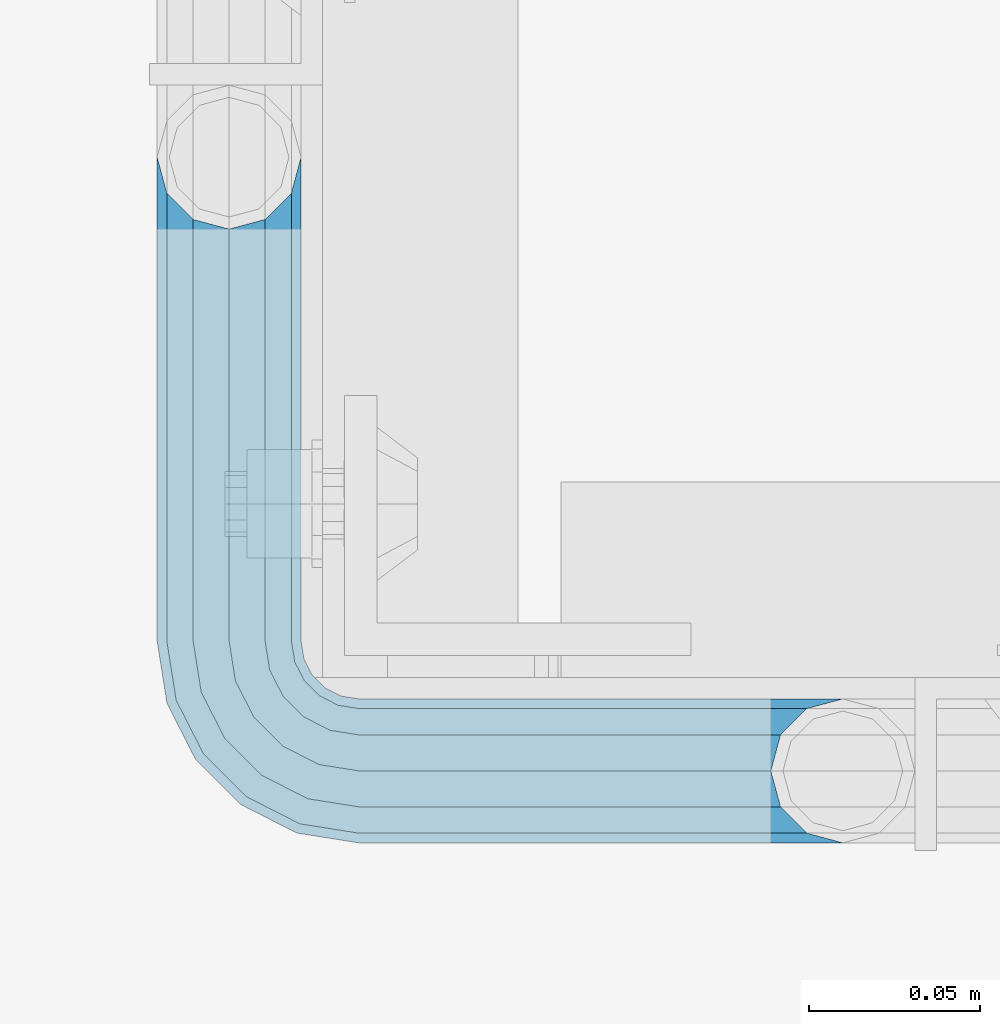
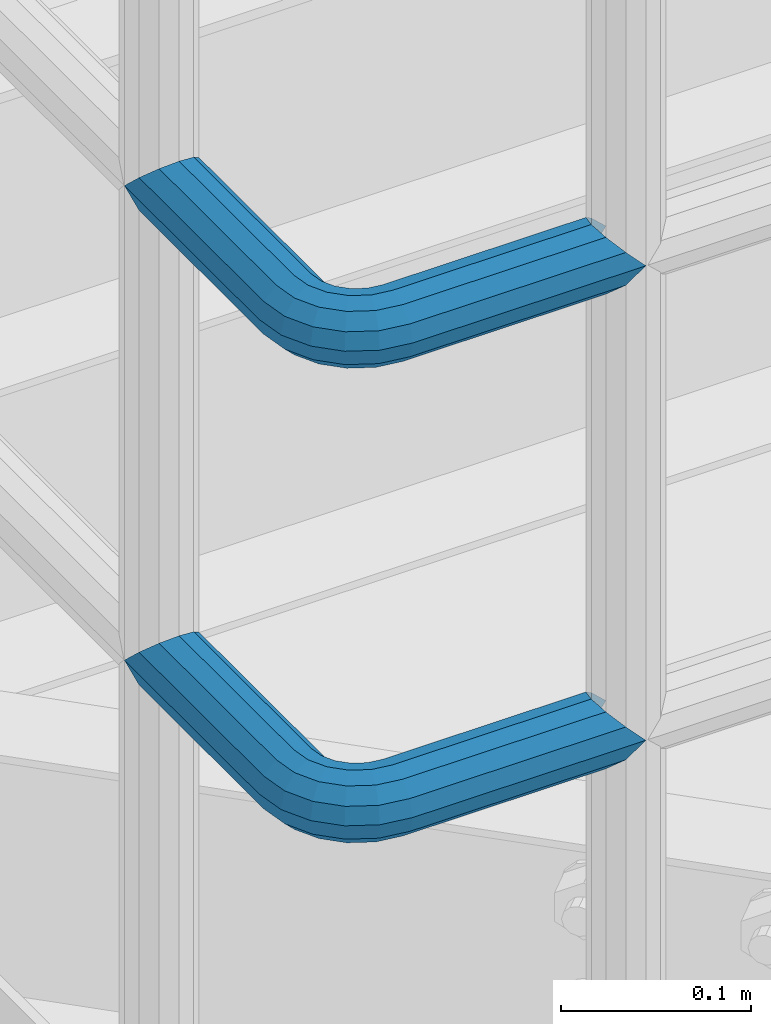
# One storey, part 1099 of 1876: 2 beams, 1 element without a shape of its own.
"""IFC2X3 building model written with IfcOpenShell, lengths in millimetres."""

from ifc_helpers import new_model, si_unit, frame, origin_with_axes, place, context, subcontext, project, spatial, faceted_brep, material, type_object, element, aggregate, save


model = new_model("IFC2X3")

# Units and contexts
model_context = context("Model", 3, precision=1e-05, world=origin_with_axes())
body_context = subcontext(model_context, "Body", "Model", "MODEL_VIEW")
ifc_project = project(units=[si_unit("LENGTHUNIT", "METRE", prefix="MILLI"), si_unit("AREAUNIT", "SQUARE_METRE"), si_unit("VOLUMEUNIT", "CUBIC_METRE"), si_unit("MASSUNIT", "GRAM", prefix="KILO"), si_unit("TIMEUNIT", "SECOND"), si_unit("PLANEANGLEUNIT", "RADIAN"), si_unit("SOLIDANGLEUNIT", "STERADIAN"), si_unit("THERMODYNAMICTEMPERATUREUNIT", "DEGREE_CELSIUS"), si_unit("LUMINOUSINTENSITYUNIT", "LUMEN")], contexts=[model_context])

# Site, building, storey
site_placement = place(None, origin_with_axes())
site = spatial("IfcSite", under=ifc_project, at=site_placement, CompositionType="ELEMENT")
building_placement = place(site_placement, origin_with_axes())
building = spatial("IfcBuilding", under=site, at=building_placement, Name="Undefined", CompositionType="ELEMENT")
storey_placement = place(building_placement, origin_with_axes())
storey = spatial("IfcBuildingStorey", under=building, at=storey_placement, Name="Undefined", CompositionType="ELEMENT", Elevation=0.0)

# Assembly, beams
assembly_placement = place(storey_placement, origin_with_axes())
assembly = element("IfcElementAssembly", 1, at=assembly_placement, inside=storey, Name="HANDRAIL", AssemblyPlace="NOTDEFINED", PredefinedType="RIGID_FRAME")
ifc_material = material()
beam_type = type_object("IfcBeamType", Name="PIPE1-1/4STD", PredefinedType="NOTDEFINED")
beam_1_placement = place(assembly_placement, frame((3338.06943150122, -15252.6644042969, 8480.425), z_axis=(0.0, 0.0, -1.0), x_axis=(0.0, -1.0, 0.0)))
beam_1 = element("IfcBeam", 2, at=beam_1_placement, type_object=beam_type, material=ifc_material, Name="HANDRAIL", ObjectType="PIPE1-1/4STD", context=body_context, shape_type="Brep", body=[
    faceted_brep([(9.09494701772928e-13, 21.0820000000003, 0.0), (10.5409999957128, 18.2575475579433, -10.5409999999993), (10.5409999999983, 18.2575475625836, 10.5410000000011), (10.5409999999983, -18.2575475625836, 10.5410000000011), (10.5409999957128, -18.2575475672238, -10.5409999999993), (9.09494701772928e-13, -21.0820000000003, 0.0), (18.2575475625817, -10.5410000000011, 18.2575475625836), (18.2575475625817, -10.5409999999974, 13.3999612267289), (13.6205863358537, -15.1779612267255, 8.76300000000083), (11.2725475625793, -17.5259999999998, 0.0), (13.6205863358537, -15.1779612267255, -8.76299999999901), (18.2575475625817, -10.5409999999974, -13.3999612267271), (18.2575475625817, -10.5410000000011, -18.2575475625836), (21.0819999999985, 0.0, -17.5259999999998), (21.0819999999985, 0.0, -21.0819999999985), (18.7339612267233, -8.76300000000083, -15.1779612267255), (18.7339612267251, 8.76299999999901, -15.1779612267255), (18.2575475625817, 10.5410000000011, -13.3999612267235), (18.2575475625817, 10.5409999999993, -18.2575475625836), (13.6205863358573, 15.1779612267255, -8.76299999999901), (11.2725475625839, 17.5259999999998, 0.0), (13.6205863358573, 15.1779612267255, 8.76300000000083), (18.2575475625817, 10.5410000000011, 13.3999612267253), (18.2575475625817, 10.5409999999993, 18.2575475625836), (18.7339612267251, 8.76299999999901, 15.1779612267273), (21.0819999999985, 1.81898940354586e-12, 17.5259999999998), (21.0819999999985, 1.81898940354586e-12, 21.0820000000003), (18.7339612267233, -8.76300000000083, 15.1779612267273), (141.7320022583, -8.7629999999981, 15.1779612267255), (141.7320022583, 1.81898940354586e-12, 17.525999999998), (153.505549272468, -1.86474665447258, 17.525999999998), (150.797633350759, -10.1988549067664, 15.1779612267237), (141.7320022583, -15.1779612267246, 8.76299999999901), (148.815301313444, -16.2998455832249, 8.76299999999901), (141.732002258301, -17.5259999999989, -1.81898940354586e-12), (148.08971742905, -18.5329631590612, -1.81898940354586e-12), (141.7320022583, -15.1779612267246, -8.76300000000083), (148.815301313443, -16.2998455832249, -8.76300000000083), (141.7320022583, -8.76299999999901, -15.1779612267273), (150.797633350759, -10.1988549067664, -15.1779612267273), (141.7320022583, 1.81898940354586e-12, -17.5260000000017), (153.505549272467, -1.86474665447258, -17.5260000000017), (141.7320022583, 8.76300000000174, -15.1779612267273), (156.213465194176, 6.46936159782217, -15.1779612267273), (141.7320022583, 15.1779612267273, -8.76300000000083), (158.195797231491, 12.5703522742806, -8.76300000000083), (141.7320022583, 17.5260000000017, -1.81898940354586e-12), (158.921381115884, 14.803469850116, -1.81898940354586e-12), (141.7320022583, 15.1779612267273, 8.76299999999901), (158.195797231491, 12.5703522742806, 8.76299999999901), (141.7320022583, 8.76300000000174, 15.1779612267255), (156.213465194176, 6.46936159782217, 15.1779612267237), (179.832000732422, -38.0999984741202, -17.5260000000017), (171.069000732422, -38.0999984741202, -15.1779612267273), (171.069000732422, -161.097989750122, -15.1779612267255), (179.832000732422, -158.7499511731, -17.5259999999998), (188.595000732423, -38.0999984741202, -15.1779612267273), (188.595000732422, -161.097990142627, -15.1779612267255), (169.291000732422, -38.0999984741202, -18.2575475625854), (179.832000732422, -38.0999984741202, -21.0820000000003), (179.832000732422, -158.7499511731, -21.0820000000003), (169.291000732422, -161.574403610517, -18.2575475625836), (161.574453169838, -38.0999984741193, -10.5410000000011), (161.574453169838, -169.2909511731, -10.5409999999993), (158.750000732422, -38.0999984741193, -1.81898940354586e-12), (158.750000732422, -179.831954956055, 0.0), (161.574453169838, -169.2909511731, 10.5409999999993), (161.574453169839, -38.0999984741193, 10.5409999999993), (169.291000732423, -38.0999984741193, 18.2575475625817), (169.291000732422, -161.574403610517, 18.2575475625836), (179.832000732423, -38.0999984741193, 21.0819999999985), (179.832000732422, -158.7499511731, 21.0820000000003), (141.7320022583, 10.5410000000011, 18.2575475625817), (141.7320022583, 18.2575475625854, 10.5409999999993), (141.7320022583, 21.0820000000012, -1.81898940354586e-12), (141.7320022583, 18.2575475625854, -10.5410000000011), (141.7320022583, 10.5410000000011, -18.2575475625854), (141.7320022583, 1.81898940354586e-12, -21.0820000000022), (141.7320022583, -10.5409999999983, -18.2575475625854), (141.7320022583, -18.2575475625817, -10.5410000000011), (141.732002258301, -21.0819999999985, -1.81898940354586e-12), (141.7320022583, -18.2575475625817, 10.5409999999993), (141.7320022583, -10.5409999999983, 18.2575475625817), (141.7320022583, 1.81898940354586e-12, 21.0819999999985), (153.505549272468, -1.86474665447258, 21.0819999999985), (156.762897410175, 8.16034008379484, 18.2575475625817), (159.147441744916, 15.4992129264911, 10.5409999999993), (160.020245547882, 18.1854268220623, -1.81898940354586e-12), (159.147441744916, 15.4992129264911, -10.5410000000011), (156.762897410174, 8.16034008379484, -18.2575475625854), (153.505549272467, -1.86474665447258, -21.0820000000022), (150.24820113476, -11.8898333927391, -18.2575475625854), (147.863656800018, -19.2287062354353, -10.5410000000011), (146.990852997053, -21.9149201310065, -1.81898940354586e-12), (147.863656800019, -19.2287062354362, 10.5409999999993), (150.248201134761, -11.8898333927391, 18.2575475625817), (157.930775129339, -15.8043003606008, 18.2575475625817), (164.126619473753, -7.27645222289357, 21.0819999999985), (153.395102273439, -22.0471184766338, 10.5409999999993), (151.734930784924, -24.332148498308, -1.81898940354586e-12), (153.395102273439, -22.0471184766338, -10.5410000000011), (157.930775129338, -15.8043003606008, -18.2575475625854), (164.126619473752, -7.27645222289357, -21.0820000000022), (170.322463818167, 1.25139591481275, -18.2575475625854), (174.858136674066, 7.49421403084671, -10.5410000000011), (176.518308162581, 9.77924405251997, -1.81898940354586e-12), (174.858136674067, 7.49421403084671, 10.5409999999993), (170.322463818167, 1.25139591481275, 18.2575475625817), (172.555548509522, -15.7053812586619, 21.0819999999985), (181.083396647228, -9.50953691424547, 18.2575475625817), (164.027700371817, -21.9012256030774, 18.2575475625817), (157.784882255784, -26.4368984589782, 10.5409999999993), (155.499852234111, -28.0970699474938, -1.81898940354586e-12), (157.784882255784, -26.4368984589782, -10.5410000000011), (164.027700371817, -21.9012256030774, -18.2575475625854), (172.555548509522, -15.7053812586619, -21.0820000000022), (181.083396647228, -9.50953691424547, -18.2575475625854), (187.32621476326, -4.97386405834459, -10.5410000000011), (189.611244784934, -3.31369256982998, -1.81898940354586e-12), (187.32621476326, -4.97386405834459, 10.5409999999993), (187.992340816218, -23.0691033222502, 18.2575475625817), (195.331213658914, -20.6845589875093, 10.5409999999993), (177.96725407795, -26.3264514599559, 21.0819999999985), (167.942167339683, -29.5837995976626, 18.2575475625817), (160.603294496986, -31.9683439324035, 10.5409999999993), (157.917080601415, -32.8411477353693, -1.81898940354586e-12), (160.603294496986, -31.9683439324035, -10.5410000000011), (167.942167339682, -29.5837995976635, -18.2575475625854), (177.96725407795, -26.3264514599568, -21.0820000000022), (187.992340816217, -23.0691033222511, -18.2575475625854), (195.331213658914, -20.6845589875093, -10.5410000000011), (198.017427554485, -19.8117551845444, -1.81898940354586e-12), (198.089548295007, -38.0999984741193, 10.5409999999993), (200.914000732423, -38.0999984741202, -1.81898940354586e-12), (190.373000732423, -38.0999984741193, 18.2575475625817), (190.373000732422, -38.0999984741202, -18.2575475625854), (198.089548295006, -38.0999984741202, -10.5410000000011), (200.913999999997, -179.831951173101, 0.0), (198.089548295005, -169.2909511731, -10.5409999999993), (190.373000732422, -161.574403610517, -18.2575475625836), (190.372999999998, -161.574403610517, -13.3999619591505), (169.290999999997, -161.574403610517, -13.3999604943019), (164.654039505696, -38.0999984741193, -8.76300000000083), (164.654039505696, -166.211364104819, -8.76300000000083), (162.306000732422, -38.0999984741193, -1.81898940354586e-12), (162.306000732422, -168.559402878092, 0.0), (164.654039505696, -166.211364104819, 8.76299999999901), (169.290999999997, -161.574403610517, 13.3999604943019), (164.654039505696, -38.0999984741193, 8.76299999999901), (171.069000732422, -38.0999984741193, 15.1779612267255), (171.069000732422, -161.097989750122, 15.1779612267255), (179.832000732422, -158.7499511731, 17.5259999999998), (179.832000732423, -38.0999984741193, 17.525999999998), (188.595000732423, -38.0999984741193, 15.1779612267255), (188.595000732422, -161.097990142627, 15.1779612267255), (197.358000732423, -38.0999984741202, -1.81898940354586e-12), (195.009961959149, -38.0999984741202, -8.76300000000083), (195.009961959148, -166.211365569668, -8.76300000000083), (197.358000732422, -168.559404342942, 0.0), (195.009961959149, -38.0999984741193, 8.76299999999901), (195.009961959148, -166.211365569668, 8.76299999999901), (190.372999999998, -161.574403610517, 13.3999619591505), (190.373000732422, -161.574403610517, 18.2575475625836), (198.089548295005, -169.2909511731, 10.5409999999993), (186.301362330245, -23.6185355382495, -15.1779612267273), (192.402353006703, -21.6362035009342, -8.76300000000083), (177.96725407795, -26.3264514599568, -17.5260000000017), (169.633145825655, -29.0343673816642, -15.1779612267273), (163.532155149196, -31.0166994189794, -8.76300000000083), (161.299037573361, -31.7422833033716, -1.81898940354586e-12), (163.532155149197, -31.0166994189785, 8.76299999999901), (169.633145825655, -29.0343673816642, 15.1779612267255), (177.96725407795, -26.3264514599568, 17.525999999998), (186.301362330245, -23.6185355382486, 15.1779612267255), (192.402353006703, -21.6362035009342, 8.76299999999901), (194.635470582539, -20.9106196165412, -1.81898940354586e-12), (184.834777081907, -6.78399948972401, -8.76300000000083), (186.734380352937, -5.40385692698237, -1.81898940354586e-12), (179.644964431229, -10.5546190928217, -15.1779612267273), (172.555548509522, -15.7053812586619, -17.5260000000017), (165.466132587815, -20.8561434245012, -15.1779612267273), (160.276319937137, -24.6267630275997, -8.76300000000083), (158.376716666108, -26.0069055903414, -1.81898940354586e-12), (160.276319937138, -24.6267630275997, 8.76299999999901), (165.466132587815, -20.8561434245012, 15.1779612267237), (172.555548509522, -15.7053812586619, 17.525999999998), (179.64496443123, -10.5546190928217, 15.1779612267237), (184.834777081907, -6.7839994897231, 8.76299999999901), (174.428143805429, 6.90237962052288, -1.81898940354586e-12), (173.048001242688, 5.00277634949271, 8.76299999999901), (173.048001242688, 5.00277634949271, -8.76300000000083), (169.277381639591, -0.187036301185799, -15.1779612267273), (164.126619473753, -7.27645222289357, -17.5260000000017), (158.975857307914, -14.3658681446022, -15.1779612267273), (155.205237704817, -19.5556807952798, -8.76300000000083), (153.825095142076, -21.45528406631, -1.81898940354586e-12), (155.205237704817, -19.5556807952798, 8.76299999999901), (158.975857307914, -14.3658681446022, 15.1779612267237), (164.126619473753, -7.27645222289357, 17.525999999998), (169.277381639591, -0.187036301185799, 15.1779612267237)], [[[0, 1, 2]], [[3, 4, 5]], [[6, 7, 8, 9, 10, 11, 12, 4, 3]], [[13, 14, 12, 11, 15]], [[16, 17, 18, 14, 13]], [[2, 1, 18, 17, 19, 20, 21, 22, 23]], [[23, 22, 24, 25, 26]], [[26, 25, 27, 7, 6]], [[28, 29, 30, 31]], [[32, 28, 31, 33]], [[34, 32, 33, 35]], [[36, 34, 35, 37]], [[38, 36, 37, 39]], [[40, 38, 39, 41]], [[42, 40, 41, 43]], [[44, 42, 43, 45]], [[46, 44, 45, 47]], [[48, 46, 47, 49]], [[50, 48, 49, 51]], [[52, 53, 54, 55]], [[56, 52, 55, 57]], [[58, 59, 60, 61]], [[62, 58, 61, 63]], [[64, 62, 63, 65]], [[65, 63, 66]], [[67, 64, 65, 66]], [[68, 67, 66, 69]], [[70, 68, 69, 71]], [[72, 73, 2, 23]], [[73, 74, 0, 2]], [[74, 75, 1, 0]], [[75, 76, 18, 1]], [[76, 77, 14, 18]], [[77, 78, 12, 14]], [[78, 79, 4, 12]], [[79, 80, 5, 4]], [[80, 81, 3, 5]], [[81, 82, 6, 3]], [[82, 83, 26, 6]], [[83, 72, 23, 26]], [[72, 83, 84, 85]], [[73, 72, 85, 86]], [[74, 73, 86, 87]], [[75, 74, 87, 88]], [[76, 75, 88, 89]], [[77, 76, 89, 90]], [[78, 77, 90, 91]], [[79, 78, 91, 92]], [[80, 79, 92, 93]], [[81, 80, 93, 94]], [[82, 81, 94, 95]], [[83, 82, 95, 84]], [[95, 96, 97, 84]], [[94, 98, 96, 95]], [[93, 99, 98, 94]], [[92, 100, 99, 93]], [[91, 101, 100, 92]], [[90, 102, 101, 91]], [[89, 103, 102, 90]], [[88, 104, 103, 89]], [[87, 105, 104, 88]], [[86, 106, 105, 87]], [[85, 107, 106, 86]], [[84, 97, 107, 85]], [[97, 108, 109, 107]], [[96, 110, 108, 97]], [[98, 111, 110, 96]], [[99, 112, 111, 98]], [[100, 113, 112, 99]], [[101, 114, 113, 100]], [[102, 115, 114, 101]], [[103, 116, 115, 102]], [[104, 117, 116, 103]], [[105, 118, 117, 104]], [[106, 119, 118, 105]], [[107, 109, 119, 106]], [[109, 120, 121, 119]], [[108, 122, 120, 109]], [[110, 123, 122, 108]], [[111, 124, 123, 110]], [[112, 125, 124, 111]], [[113, 126, 125, 112]], [[114, 127, 126, 113]], [[115, 128, 127, 114]], [[116, 129, 128, 115]], [[117, 130, 129, 116]], [[118, 131, 130, 117]], [[119, 121, 131, 118]], [[121, 132, 133, 131]], [[120, 134, 132, 121]], [[122, 70, 134, 120]], [[123, 68, 70, 122]], [[124, 67, 68, 123]], [[125, 64, 67, 124]], [[126, 62, 64, 125]], [[127, 58, 62, 126]], [[128, 59, 58, 127]], [[129, 135, 59, 128]], [[130, 136, 135, 129]], [[131, 133, 136, 130]], [[136, 133, 137, 138]], [[135, 136, 138, 139]], [[59, 135, 139, 60]], [[57, 55, 60, 139, 140]], [[54, 141, 61, 60, 55]], [[53, 142, 143, 141, 54]], [[142, 144, 145, 143]], [[66, 63, 61, 141, 143, 145, 146, 147, 69]], [[144, 148, 146, 145]], [[146, 148, 149, 150, 147]], [[69, 147, 150, 151, 71]], [[149, 152, 151, 150]], [[152, 153, 154, 151]], [[155, 156, 157, 158]], [[159, 155, 158, 160]], [[154, 153, 159, 160, 161]], [[71, 151, 154, 161, 162]], [[134, 70, 71, 162]], [[132, 134, 162, 163]], [[133, 132, 163, 137]], [[137, 163, 138]], [[162, 161, 160, 158, 157, 140, 139, 138, 163]], [[156, 56, 57, 140, 157]], [[164, 56, 156, 165]], [[166, 52, 56, 164]], [[167, 53, 52, 166]], [[168, 142, 53, 167]], [[169, 144, 142, 168]], [[170, 148, 144, 169]], [[171, 149, 148, 170]], [[172, 152, 149, 171]], [[173, 153, 152, 172]], [[174, 159, 153, 173]], [[175, 155, 159, 174]], [[165, 156, 155, 175]], [[176, 165, 175, 177]], [[178, 164, 165, 176]], [[179, 166, 164, 178]], [[180, 167, 166, 179]], [[181, 168, 167, 180]], [[182, 169, 168, 181]], [[183, 170, 169, 182]], [[184, 171, 170, 183]], [[185, 172, 171, 184]], [[186, 173, 172, 185]], [[187, 174, 173, 186]], [[177, 175, 174, 187]], [[188, 177, 187, 189]], [[190, 176, 177, 188]], [[191, 178, 176, 190]], [[192, 179, 178, 191]], [[193, 180, 179, 192]], [[194, 181, 180, 193]], [[195, 182, 181, 194]], [[196, 183, 182, 195]], [[197, 184, 183, 196]], [[198, 185, 184, 197]], [[199, 186, 185, 198]], [[189, 187, 186, 199]], [[49, 189, 199, 51]], [[47, 188, 189, 49]], [[45, 190, 188, 47]], [[43, 191, 190, 45]], [[41, 192, 191, 43]], [[39, 193, 192, 41]], [[37, 194, 193, 39]], [[35, 195, 194, 37]], [[33, 196, 195, 35]], [[31, 197, 196, 33]], [[30, 198, 197, 31]], [[51, 199, 198, 30]], [[29, 50, 51, 30]], [[50, 29, 25, 24]], [[21, 48, 50, 24, 22]], [[46, 48, 21, 20]], [[44, 46, 20, 19]], [[42, 44, 19, 17, 16]], [[40, 42, 16, 13]], [[38, 40, 13, 15]], [[10, 36, 38, 15, 11]], [[34, 36, 10, 9]], [[32, 34, 9, 8]], [[28, 32, 8, 7, 27]], [[29, 28, 27, 25]]]),
])
beam_2_placement = place(assembly_placement, frame((3338.06943150122, -15252.6644042969, 8785.225), z_axis=(0.0, 0.0, -1.0), x_axis=(0.0, -1.0, 0.0)))
beam_2 = element("IfcBeam", 3, at=beam_2_placement, type_object=beam_type, material=ifc_material, Name="HANDRAIL", ObjectType="PIPE1-1/4STD", context=body_context, shape_type="Brep", body=[
    faceted_brep([(9.09494701772928e-13, 21.0820000000003, 0.0), (10.5409999957128, 18.2575475579433, -10.5409999999993), (10.5409999999983, 18.2575475625836, 10.5410000000011), (10.5409999999983, -18.2575475625836, 10.5410000000011), (10.5409999957128, -18.2575475672238, -10.5409999999993), (9.09494701772928e-13, -21.0820000000003, 0.0), (18.2575475625817, -10.5410000000011, 18.2575475625836), (18.2575475625817, -10.5409999999974, 13.3999612267289), (13.6205863358537, -15.1779612267255, 8.76300000000083), (11.2725475625793, -17.5259999999998, 0.0), (13.6205863358537, -15.1779612267255, -8.76299999999901), (18.2575475625817, -10.5409999999974, -13.3999612267271), (18.2575475625817, -10.5410000000011, -18.2575475625836), (21.0819999999985, 0.0, -17.5259999999998), (21.0819999999985, 0.0, -21.0819999999985), (18.7339612267233, -8.76300000000083, -15.1779612267255), (18.7339612267251, 8.76299999999901, -15.1779612267255), (18.2575475625817, 10.5410000000011, -13.3999612267235), (18.2575475625817, 10.5409999999993, -18.2575475625836), (13.6205863358573, 15.1779612267255, -8.76299999999901), (11.2725475625839, 17.5259999999998, 0.0), (13.6205863358573, 15.1779612267255, 8.76300000000083), (18.2575475625817, 10.5410000000011, 13.3999612267253), (18.2575475625817, 10.5409999999993, 18.2575475625836), (18.7339612267251, 8.76299999999901, 15.1779612267273), (21.0819999999985, 1.81898940354586e-12, 17.5259999999998), (21.0819999999985, 1.81898940354586e-12, 21.0820000000003), (18.7339612267233, -8.76300000000083, 15.1779612267273), (141.7320022583, -8.7629999999981, 15.1779612267255), (141.7320022583, 1.81898940354586e-12, 17.525999999998), (153.505549272468, -1.86474665447258, 17.525999999998), (150.797633350759, -10.1988549067664, 15.1779612267237), (141.7320022583, -15.1779612267246, 8.76299999999901), (148.815301313444, -16.2998455832249, 8.76299999999901), (141.732002258301, -17.5259999999989, -1.81898940354586e-12), (148.08971742905, -18.5329631590612, -1.81898940354586e-12), (141.7320022583, -15.1779612267246, -8.76300000000083), (148.815301313443, -16.2998455832249, -8.76300000000083), (141.7320022583, -8.76299999999901, -15.1779612267273), (150.797633350759, -10.1988549067664, -15.1779612267273), (141.7320022583, 1.81898940354586e-12, -17.5260000000017), (153.505549272467, -1.86474665447258, -17.5260000000017), (141.7320022583, 8.76300000000174, -15.1779612267273), (156.213465194176, 6.46936159782217, -15.1779612267273), (141.7320022583, 15.1779612267273, -8.76300000000083), (158.195797231491, 12.5703522742806, -8.76300000000083), (141.7320022583, 17.5260000000017, -1.81898940354586e-12), (158.921381115884, 14.803469850116, -1.81898940354586e-12), (141.7320022583, 15.1779612267273, 8.76299999999901), (158.195797231491, 12.5703522742806, 8.76299999999901), (141.7320022583, 8.76300000000174, 15.1779612267255), (156.213465194176, 6.46936159782217, 15.1779612267237), (179.832000732422, -38.0999984741202, -17.5260000000017), (171.069000732422, -38.0999984741202, -15.1779612267273), (171.069000732422, -161.097989750122, -15.1779612267255), (179.832000732422, -158.7499511731, -17.5259999999998), (188.595000732423, -38.0999984741202, -15.1779612267273), (188.595000732422, -161.097990142627, -15.1779612267255), (169.291000732422, -38.0999984741202, -18.2575475625854), (179.832000732422, -38.0999984741202, -21.0820000000003), (179.832000732422, -158.7499511731, -21.0820000000003), (169.291000732422, -161.574403610517, -18.2575475625836), (161.574453169838, -38.0999984741193, -10.5410000000011), (161.574453169838, -169.2909511731, -10.5409999999993), (158.750000732422, -38.0999984741193, -1.81898940354586e-12), (158.750000732422, -179.831954956055, 0.0), (161.574453169838, -169.2909511731, 10.5409999999993), (161.574453169839, -38.0999984741193, 10.5409999999993), (169.291000732423, -38.0999984741193, 18.2575475625817), (169.291000732422, -161.574403610517, 18.2575475625836), (179.832000732423, -38.0999984741193, 21.0819999999985), (179.832000732422, -158.7499511731, 21.0820000000003), (141.7320022583, 10.5410000000011, 18.2575475625817), (141.7320022583, 18.2575475625854, 10.5409999999993), (141.7320022583, 21.0820000000012, -1.81898940354586e-12), (141.7320022583, 18.2575475625854, -10.5410000000011), (141.7320022583, 10.5410000000011, -18.2575475625854), (141.7320022583, 1.81898940354586e-12, -21.0820000000022), (141.7320022583, -10.5409999999983, -18.2575475625854), (141.7320022583, -18.2575475625817, -10.5410000000011), (141.732002258301, -21.0819999999985, -1.81898940354586e-12), (141.7320022583, -18.2575475625817, 10.5409999999993), (141.7320022583, -10.5409999999983, 18.2575475625817), (141.7320022583, 1.81898940354586e-12, 21.0819999999985), (153.505549272468, -1.86474665447258, 21.0819999999985), (156.762897410175, 8.16034008379484, 18.2575475625817), (159.147441744916, 15.4992129264911, 10.5409999999993), (160.020245547882, 18.1854268220623, -1.81898940354586e-12), (159.147441744916, 15.4992129264911, -10.5410000000011), (156.762897410174, 8.16034008379484, -18.2575475625854), (153.505549272467, -1.86474665447258, -21.0820000000022), (150.24820113476, -11.8898333927391, -18.2575475625854), (147.863656800018, -19.2287062354353, -10.5410000000011), (146.990852997053, -21.9149201310065, -1.81898940354586e-12), (147.863656800019, -19.2287062354362, 10.5409999999993), (150.248201134761, -11.8898333927391, 18.2575475625817), (157.930775129339, -15.8043003606008, 18.2575475625817), (164.126619473753, -7.27645222289357, 21.0819999999985), (153.395102273439, -22.0471184766338, 10.5409999999993), (151.734930784924, -24.332148498308, -1.81898940354586e-12), (153.395102273439, -22.0471184766338, -10.5410000000011), (157.930775129338, -15.8043003606008, -18.2575475625854), (164.126619473752, -7.27645222289357, -21.0820000000022), (170.322463818167, 1.25139591481275, -18.2575475625854), (174.858136674066, 7.49421403084671, -10.5410000000011), (176.518308162581, 9.77924405251997, -1.81898940354586e-12), (174.858136674067, 7.49421403084671, 10.5409999999993), (170.322463818167, 1.25139591481275, 18.2575475625817), (172.555548509522, -15.7053812586619, 21.0819999999985), (181.083396647228, -9.50953691424547, 18.2575475625817), (164.027700371817, -21.9012256030774, 18.2575475625817), (157.784882255784, -26.4368984589782, 10.5409999999993), (155.499852234111, -28.0970699474938, -1.81898940354586e-12), (157.784882255784, -26.4368984589782, -10.5410000000011), (164.027700371817, -21.9012256030774, -18.2575475625854), (172.555548509522, -15.7053812586619, -21.0820000000022), (181.083396647228, -9.50953691424547, -18.2575475625854), (187.32621476326, -4.97386405834459, -10.5410000000011), (189.611244784934, -3.31369256982998, -1.81898940354586e-12), (187.32621476326, -4.97386405834459, 10.5409999999993), (187.992340816218, -23.0691033222502, 18.2575475625817), (195.331213658914, -20.6845589875093, 10.5409999999993), (177.96725407795, -26.3264514599559, 21.0819999999985), (167.942167339683, -29.5837995976626, 18.2575475625817), (160.603294496986, -31.9683439324035, 10.5409999999993), (157.917080601415, -32.8411477353693, -1.81898940354586e-12), (160.603294496986, -31.9683439324035, -10.5410000000011), (167.942167339682, -29.5837995976635, -18.2575475625854), (177.96725407795, -26.3264514599568, -21.0820000000022), (187.992340816217, -23.0691033222511, -18.2575475625854), (195.331213658914, -20.6845589875093, -10.5410000000011), (198.017427554485, -19.8117551845444, -1.81898940354586e-12), (198.089548295007, -38.0999984741193, 10.5409999999993), (200.914000732423, -38.0999984741202, -1.81898940354586e-12), (190.373000732423, -38.0999984741193, 18.2575475625817), (190.373000732422, -38.0999984741202, -18.2575475625854), (198.089548295006, -38.0999984741202, -10.5410000000011), (200.913999999997, -179.831951173101, 0.0), (198.089548295005, -169.2909511731, -10.5409999999993), (190.373000732422, -161.574403610517, -18.2575475625836), (190.372999999998, -161.574403610517, -13.3999619591505), (169.290999999997, -161.574403610517, -13.3999604943019), (164.654039505696, -38.0999984741193, -8.76300000000083), (164.654039505696, -166.211364104819, -8.76300000000083), (162.306000732422, -38.0999984741193, -1.81898940354586e-12), (162.306000732422, -168.559402878092, 0.0), (164.654039505696, -166.211364104819, 8.76299999999901), (169.290999999997, -161.574403610517, 13.3999604943019), (164.654039505696, -38.0999984741193, 8.76299999999901), (171.069000732422, -38.0999984741193, 15.1779612267255), (171.069000732422, -161.097989750122, 15.1779612267255), (179.832000732422, -158.7499511731, 17.5259999999998), (179.832000732423, -38.0999984741193, 17.525999999998), (188.595000732423, -38.0999984741193, 15.1779612267255), (188.595000732422, -161.097990142627, 15.1779612267255), (197.358000732423, -38.0999984741202, -1.81898940354586e-12), (195.009961959149, -38.0999984741202, -8.76300000000083), (195.009961959148, -166.211365569668, -8.76300000000083), (197.358000732422, -168.559404342942, 0.0), (195.009961959149, -38.0999984741193, 8.76299999999901), (195.009961959148, -166.211365569668, 8.76299999999901), (190.372999999998, -161.574403610517, 13.3999619591505), (190.373000732422, -161.574403610517, 18.2575475625836), (198.089548295005, -169.2909511731, 10.5409999999993), (186.301362330245, -23.6185355382495, -15.1779612267273), (192.402353006703, -21.6362035009342, -8.76300000000083), (177.96725407795, -26.3264514599568, -17.5260000000017), (169.633145825655, -29.0343673816642, -15.1779612267273), (163.532155149196, -31.0166994189794, -8.76300000000083), (161.299037573361, -31.7422833033716, -1.81898940354586e-12), (163.532155149197, -31.0166994189785, 8.76299999999901), (169.633145825655, -29.0343673816642, 15.1779612267255), (177.96725407795, -26.3264514599568, 17.525999999998), (186.301362330245, -23.6185355382486, 15.1779612267255), (192.402353006703, -21.6362035009342, 8.76299999999901), (194.635470582539, -20.9106196165412, -1.81898940354586e-12), (184.834777081907, -6.78399948972401, -8.76300000000083), (186.734380352937, -5.40385692698237, -1.81898940354586e-12), (179.644964431229, -10.5546190928217, -15.1779612267273), (172.555548509522, -15.7053812586619, -17.5260000000017), (165.466132587815, -20.8561434245012, -15.1779612267273), (160.276319937137, -24.6267630275997, -8.76300000000083), (158.376716666108, -26.0069055903414, -1.81898940354586e-12), (160.276319937138, -24.6267630275997, 8.76299999999901), (165.466132587815, -20.8561434245012, 15.1779612267237), (172.555548509522, -15.7053812586619, 17.525999999998), (179.64496443123, -10.5546190928217, 15.1779612267237), (184.834777081907, -6.7839994897231, 8.76299999999901), (174.428143805429, 6.90237962052288, -1.81898940354586e-12), (173.048001242688, 5.00277634949271, 8.76299999999901), (173.048001242688, 5.00277634949271, -8.76300000000083), (169.277381639591, -0.187036301185799, -15.1779612267273), (164.126619473753, -7.27645222289357, -17.5260000000017), (158.975857307914, -14.3658681446022, -15.1779612267273), (155.205237704817, -19.5556807952798, -8.76300000000083), (153.825095142076, -21.45528406631, -1.81898940354586e-12), (155.205237704817, -19.5556807952798, 8.76299999999901), (158.975857307914, -14.3658681446022, 15.1779612267237), (164.126619473753, -7.27645222289357, 17.525999999998), (169.277381639591, -0.187036301185799, 15.1779612267237)], [[[0, 1, 2]], [[3, 4, 5]], [[6, 7, 8, 9, 10, 11, 12, 4, 3]], [[13, 14, 12, 11, 15]], [[16, 17, 18, 14, 13]], [[2, 1, 18, 17, 19, 20, 21, 22, 23]], [[23, 22, 24, 25, 26]], [[26, 25, 27, 7, 6]], [[28, 29, 30, 31]], [[32, 28, 31, 33]], [[34, 32, 33, 35]], [[36, 34, 35, 37]], [[38, 36, 37, 39]], [[40, 38, 39, 41]], [[42, 40, 41, 43]], [[44, 42, 43, 45]], [[46, 44, 45, 47]], [[48, 46, 47, 49]], [[50, 48, 49, 51]], [[52, 53, 54, 55]], [[56, 52, 55, 57]], [[58, 59, 60, 61]], [[62, 58, 61, 63]], [[64, 62, 63, 65]], [[65, 63, 66]], [[67, 64, 65, 66]], [[68, 67, 66, 69]], [[70, 68, 69, 71]], [[72, 73, 2, 23]], [[73, 74, 0, 2]], [[74, 75, 1, 0]], [[75, 76, 18, 1]], [[76, 77, 14, 18]], [[77, 78, 12, 14]], [[78, 79, 4, 12]], [[79, 80, 5, 4]], [[80, 81, 3, 5]], [[81, 82, 6, 3]], [[82, 83, 26, 6]], [[83, 72, 23, 26]], [[72, 83, 84, 85]], [[73, 72, 85, 86]], [[74, 73, 86, 87]], [[75, 74, 87, 88]], [[76, 75, 88, 89]], [[77, 76, 89, 90]], [[78, 77, 90, 91]], [[79, 78, 91, 92]], [[80, 79, 92, 93]], [[81, 80, 93, 94]], [[82, 81, 94, 95]], [[83, 82, 95, 84]], [[95, 96, 97, 84]], [[94, 98, 96, 95]], [[93, 99, 98, 94]], [[92, 100, 99, 93]], [[91, 101, 100, 92]], [[90, 102, 101, 91]], [[89, 103, 102, 90]], [[88, 104, 103, 89]], [[87, 105, 104, 88]], [[86, 106, 105, 87]], [[85, 107, 106, 86]], [[84, 97, 107, 85]], [[97, 108, 109, 107]], [[96, 110, 108, 97]], [[98, 111, 110, 96]], [[99, 112, 111, 98]], [[100, 113, 112, 99]], [[101, 114, 113, 100]], [[102, 115, 114, 101]], [[103, 116, 115, 102]], [[104, 117, 116, 103]], [[105, 118, 117, 104]], [[106, 119, 118, 105]], [[107, 109, 119, 106]], [[109, 120, 121, 119]], [[108, 122, 120, 109]], [[110, 123, 122, 108]], [[111, 124, 123, 110]], [[112, 125, 124, 111]], [[113, 126, 125, 112]], [[114, 127, 126, 113]], [[115, 128, 127, 114]], [[116, 129, 128, 115]], [[117, 130, 129, 116]], [[118, 131, 130, 117]], [[119, 121, 131, 118]], [[121, 132, 133, 131]], [[120, 134, 132, 121]], [[122, 70, 134, 120]], [[123, 68, 70, 122]], [[124, 67, 68, 123]], [[125, 64, 67, 124]], [[126, 62, 64, 125]], [[127, 58, 62, 126]], [[128, 59, 58, 127]], [[129, 135, 59, 128]], [[130, 136, 135, 129]], [[131, 133, 136, 130]], [[136, 133, 137, 138]], [[135, 136, 138, 139]], [[59, 135, 139, 60]], [[57, 55, 60, 139, 140]], [[54, 141, 61, 60, 55]], [[53, 142, 143, 141, 54]], [[142, 144, 145, 143]], [[66, 63, 61, 141, 143, 145, 146, 147, 69]], [[144, 148, 146, 145]], [[146, 148, 149, 150, 147]], [[69, 147, 150, 151, 71]], [[149, 152, 151, 150]], [[152, 153, 154, 151]], [[155, 156, 157, 158]], [[159, 155, 158, 160]], [[154, 153, 159, 160, 161]], [[71, 151, 154, 161, 162]], [[134, 70, 71, 162]], [[132, 134, 162, 163]], [[133, 132, 163, 137]], [[137, 163, 138]], [[162, 161, 160, 158, 157, 140, 139, 138, 163]], [[156, 56, 57, 140, 157]], [[164, 56, 156, 165]], [[166, 52, 56, 164]], [[167, 53, 52, 166]], [[168, 142, 53, 167]], [[169, 144, 142, 168]], [[170, 148, 144, 169]], [[171, 149, 148, 170]], [[172, 152, 149, 171]], [[173, 153, 152, 172]], [[174, 159, 153, 173]], [[175, 155, 159, 174]], [[165, 156, 155, 175]], [[176, 165, 175, 177]], [[178, 164, 165, 176]], [[179, 166, 164, 178]], [[180, 167, 166, 179]], [[181, 168, 167, 180]], [[182, 169, 168, 181]], [[183, 170, 169, 182]], [[184, 171, 170, 183]], [[185, 172, 171, 184]], [[186, 173, 172, 185]], [[187, 174, 173, 186]], [[177, 175, 174, 187]], [[188, 177, 187, 189]], [[190, 176, 177, 188]], [[191, 178, 176, 190]], [[192, 179, 178, 191]], [[193, 180, 179, 192]], [[194, 181, 180, 193]], [[195, 182, 181, 194]], [[196, 183, 182, 195]], [[197, 184, 183, 196]], [[198, 185, 184, 197]], [[199, 186, 185, 198]], [[189, 187, 186, 199]], [[49, 189, 199, 51]], [[47, 188, 189, 49]], [[45, 190, 188, 47]], [[43, 191, 190, 45]], [[41, 192, 191, 43]], [[39, 193, 192, 41]], [[37, 194, 193, 39]], [[35, 195, 194, 37]], [[33, 196, 195, 35]], [[31, 197, 196, 33]], [[30, 198, 197, 31]], [[51, 199, 198, 30]], [[29, 50, 51, 30]], [[50, 29, 25, 24]], [[21, 48, 50, 24, 22]], [[46, 48, 21, 20]], [[44, 46, 20, 19]], [[42, 44, 19, 17, 16]], [[40, 42, 16, 13]], [[38, 40, 13, 15]], [[10, 36, 38, 15, 11]], [[34, 36, 10, 9]], [[32, 34, 9, 8]], [[28, 32, 8, 7, 27]], [[29, 28, 27, 25]]]),
])
aggregate(assembly, [beam_1, beam_2])

save(model, "model.ifc")
